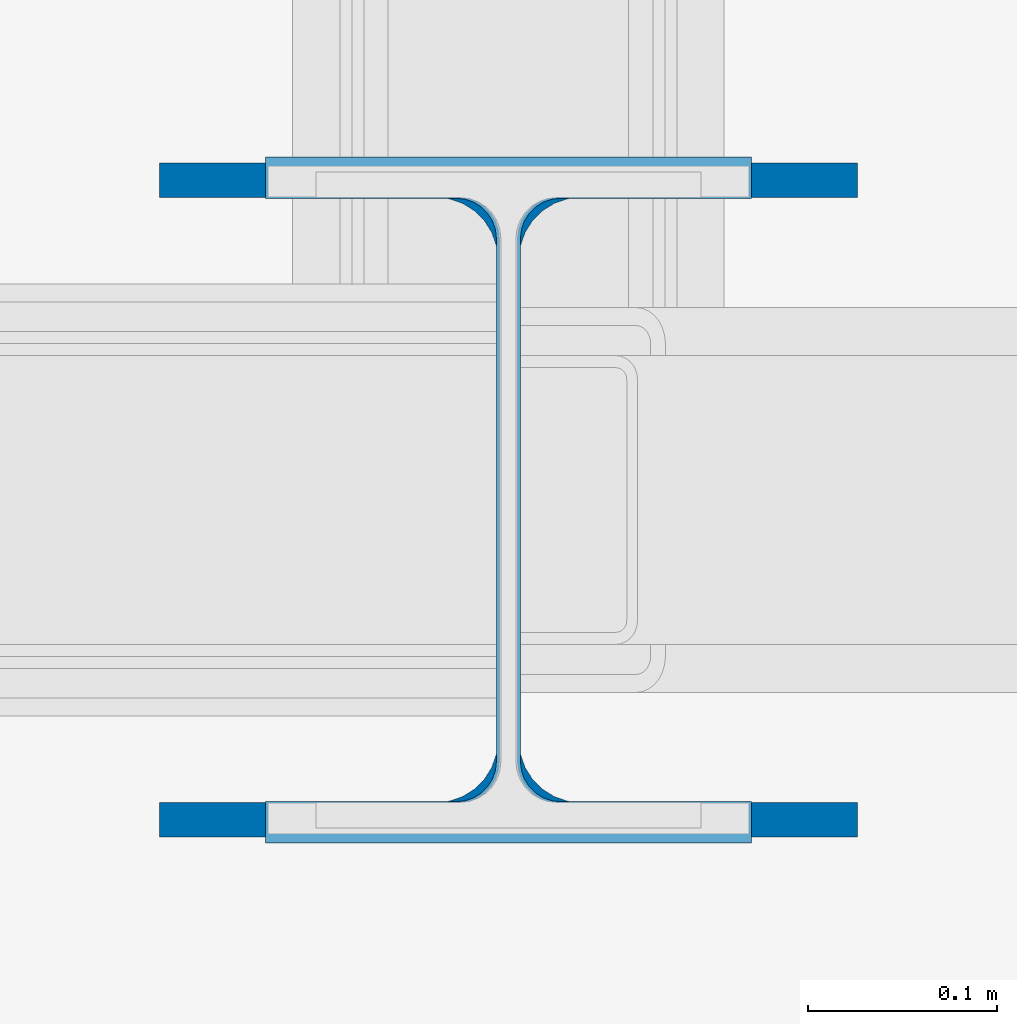
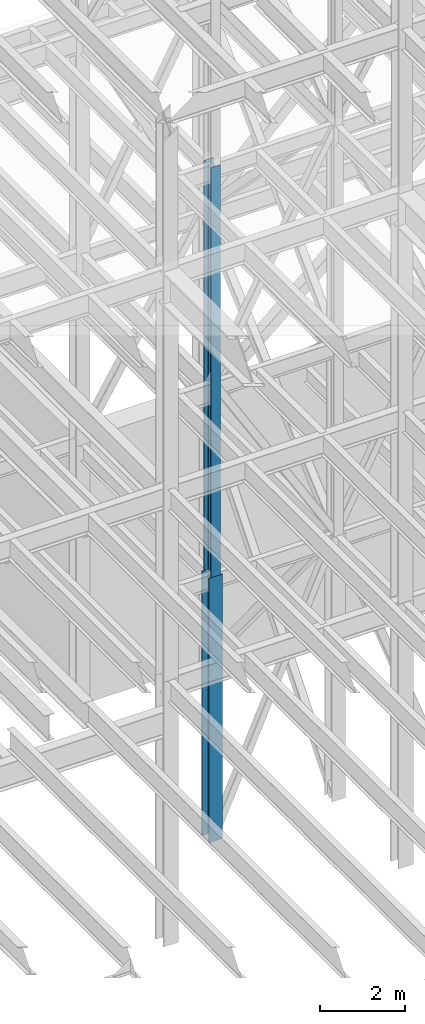
# One storey, part 41 of 150: 2 columns.
"""IFC2X3 building model written with IfcOpenShell, lengths in millimetres."""

from ifc_helpers import new_model, si_unit, frame, origin_with_axes, origin_2d_with_axis, place, context, subcontext, project, spatial, i_section, extrude, material, type_object, element, save


model = new_model("IFC2X3")

# Units and contexts
model_context = context("Model", 3, precision=1e-05, world=origin_with_axes())
body_context = subcontext(model_context, "Body", "Model", "MODEL_VIEW")
ifc_project = project(units=[si_unit("LENGTHUNIT", "METRE", prefix="MILLI"), si_unit("AREAUNIT", "SQUARE_METRE"), si_unit("VOLUMEUNIT", "CUBIC_METRE"), si_unit("MASSUNIT", "GRAM", prefix="KILO"), si_unit("TIMEUNIT", "SECOND"), si_unit("PLANEANGLEUNIT", "RADIAN"), si_unit("SOLIDANGLEUNIT", "STERADIAN"), si_unit("THERMODYNAMICTEMPERATUREUNIT", "DEGREE_CELSIUS"), si_unit("LUMINOUSINTENSITYUNIT", "LUMEN")], contexts=[model_context])

# Site, building, storey
site_placement = place(None, origin_with_axes())
site = spatial("IfcSite", under=ifc_project, at=site_placement, CompositionType="ELEMENT")
building_placement = place(site_placement, origin_with_axes())
building = spatial("IfcBuilding", under=site, at=building_placement, Name="Undefined", CompositionType="ELEMENT")
storey_placement = place(building_placement, origin_with_axes())
storey = spatial("IfcBuildingStorey", under=building, at=storey_placement, Name="Undefined", CompositionType="ELEMENT", Elevation=0.0)

# Columns
ifc_material = material(Name="STEEL/A992")
column_type_1 = type_object("IfcColumnType", Name="W14X90", PredefinedType="NOTDEFINED")
column_1_placement = place(storey_placement, frame((53238.4, 25628.6, 16154.4), z_axis=(0.0, 0.0, 1.0), x_axis=(1.0, 0.0, 0.0)))
element("IfcColumn", 1, at=column_1_placement, inside=storey, type_object=column_type_1, material=ifc_material, Name="COLUMN", ObjectType="W14X90", context=body_context, shape_type="SweptSolid", body=[
    extrude(i_section(OverallWidth=368.3, OverallDepth=355.6, WebThickness=11.1125, FlangeThickness=18.034, FilletRadius=32.7659, at=origin_2d_with_axis()), frame((0.0, 0.0, 7620.0), z_axis=(0.0, 0.0, -1.0), x_axis=(-1.0, 0.0, 0.0)), (0.0, 0.0, 1.0), 7620.0),
])
column_type_2 = type_object("IfcColumnType", Name="W14X82", PredefinedType="NOTDEFINED")
column_2_placement = place(storey_placement, frame((53238.4, 25628.6, 23774.4), z_axis=(0.0, 0.0, 1.0), x_axis=(1.0, 0.0, 0.0)))
element("IfcColumn", 2, at=column_2_placement, inside=storey, type_object=column_type_2, material=ifc_material, Name="COLUMN", ObjectType="W14X82", context=body_context, shape_type="SweptSolid", body=[
    extrude(i_section(OverallWidth=256.54, OverallDepth=361.95, WebThickness=12.6999, FlangeThickness=21.717, FilletRadius=21.1455, at=origin_2d_with_axis()), frame((0.0, 0.0, 11811.0), z_axis=(0.0, 0.0, -1.0), x_axis=(-1.0, 0.0, 0.0)), (0.0, 0.0, 1.0), 11811.0),
])

save(model, "model.ifc")
